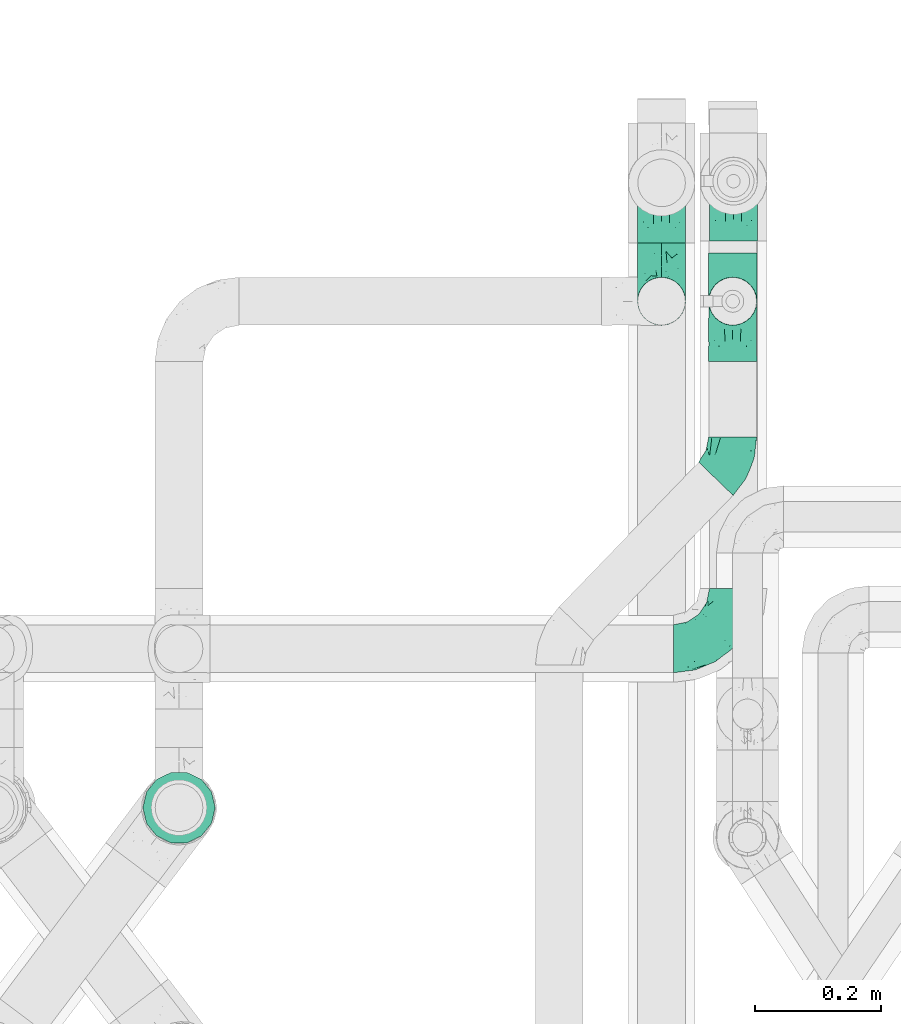
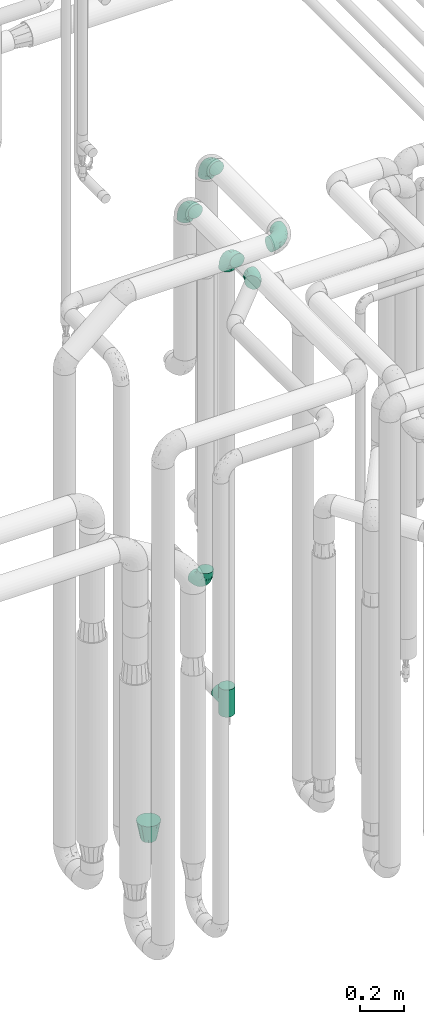
# One storey, part 672 of 827: 8 flow fittings.
"""IFC2X3 building model written with IfcOpenShell, lengths in millimetres."""

from ifc_helpers import new_model, entity, si_unit, converted_unit, derived_unit, direction, frame, origin, place, context, subcontext, project, spatial, faceted_brep, source, transform, mapped, material, type_object, type_shapes, element, save


model = new_model("IFC2X3")

# Units and contexts
model_context = context("Model", 3, precision=0.01, world=origin(), true_north=direction((6.12303176911189e-17, 1.0)))
body_context = subcontext(model_context, "Body", "Model", "MODEL_VIEW")
ifc_project = project(units=[si_unit("LENGTHUNIT", "METRE", prefix="MILLI"), si_unit("AREAUNIT", "SQUARE_METRE"), si_unit("VOLUMEUNIT", "CUBIC_METRE"), converted_unit("PLANEANGLEUNIT", "DEGREE", entity("IfcRatioMeasure", 0.0174532925199433), si_unit("PLANEANGLEUNIT", "RADIAN"), dimensions=[0, 0, 0, 0, 0, 0, 0]), si_unit("MASSUNIT", "GRAM", prefix="KILO"), derived_unit("MASSDENSITYUNIT", [(si_unit("MASSUNIT", "GRAM", prefix="KILO"), 1), (si_unit("LENGTHUNIT", "METRE"), -3)]), derived_unit("MOMENTOFINERTIAUNIT", [(si_unit("LENGTHUNIT", "METRE"), 4)]), si_unit("TIMEUNIT", "SECOND"), si_unit("FREQUENCYUNIT", "HERTZ"), si_unit("THERMODYNAMICTEMPERATUREUNIT", "DEGREE_CELSIUS"), derived_unit("THERMALTRANSMITTANCEUNIT", [(si_unit("MASSUNIT", "GRAM", prefix="KILO"), 1), (si_unit("THERMODYNAMICTEMPERATUREUNIT", "KELVIN"), -1), (si_unit("TIMEUNIT", "SECOND"), -3)]), derived_unit("VOLUMETRICFLOWRATEUNIT", [(si_unit("LENGTHUNIT", "METRE"), 3), (si_unit("TIMEUNIT", "SECOND"), -1)]), derived_unit("MASSFLOWRATEUNIT", [(si_unit("MASSUNIT", "GRAM", prefix="KILO"), 1), (si_unit("TIMEUNIT", "SECOND"), -1)]), derived_unit("ROTATIONALFREQUENCYUNIT", [(si_unit("TIMEUNIT", "SECOND"), -1)]), si_unit("ELECTRICCURRENTUNIT", "AMPERE"), si_unit("ELECTRICVOLTAGEUNIT", "VOLT"), si_unit("POWERUNIT", "WATT"), si_unit("FORCEUNIT", "NEWTON", prefix="KILO"), si_unit("ILLUMINANCEUNIT", "LUX"), si_unit("LUMINOUSFLUXUNIT", "LUMEN"), si_unit("LUMINOUSINTENSITYUNIT", "CANDELA"), derived_unit("USERDEFINED", [(si_unit("MASSUNIT", "GRAM", prefix="KILO"), -1), (si_unit("LENGTHUNIT", "METRE"), -2), (si_unit("TIMEUNIT", "SECOND"), 3), (si_unit("LUMINOUSFLUXUNIT", "LUMEN"), 1)]), derived_unit("LINEARVELOCITYUNIT", [(si_unit("LENGTHUNIT", "METRE"), 1), (si_unit("TIMEUNIT", "SECOND"), -1)]), si_unit("PRESSUREUNIT", "PASCAL"), derived_unit("USERDEFINED", [(si_unit("LENGTHUNIT", "METRE"), -2), (si_unit("MASSUNIT", "GRAM", prefix="KILO"), 1), (si_unit("TIMEUNIT", "SECOND"), -2)]), derived_unit("LINEARFORCEUNIT", [(si_unit("MASSUNIT", "GRAM", prefix="KILO"), 1), (si_unit("LENGTHUNIT", "METRE"), 1), (si_unit("TIMEUNIT", "SECOND"), -2), (si_unit("LENGTHUNIT", "METRE"), -1)]), derived_unit("PLANARFORCEUNIT", [(si_unit("MASSUNIT", "GRAM", prefix="KILO"), 1), (si_unit("LENGTHUNIT", "METRE"), 1), (si_unit("TIMEUNIT", "SECOND"), -2), (si_unit("LENGTHUNIT", "METRE"), -2)])], contexts=[model_context])

# Site, building, storey
site_placement = place(None, origin())
site = spatial("IfcSite", under=ifc_project, at=site_placement, CompositionType="ELEMENT")
building_placement = place(site_placement, origin())
building = spatial("IfcBuilding", under=site, at=building_placement, CompositionType="ELEMENT")
storey_placement = place(building_placement, frame((0.0, 0.0, 28200.0)))
storey = spatial("IfcBuildingStorey", under=building, at=storey_placement, Name="08", CompositionType="ELEMENT", Elevation=28200.0)

# Flow fittings
ifc_material = material()
pipe_fitting_type_1 = type_object("IfcPipeFittingType", Name="ADSK_1", PredefinedType="NOTDEFINED", material=ifc_material)
shared_shape_1 = source(origin(), body_context, "Body", "Brep", [
    faceted_brep([(-95.0, 19.02, -32.95), (-95.0, 9.85, -36.75), (-95.0, 0.0, -38.05), (-95.0, -9.85, -36.75), (-95.0, -19.03, -32.95), (-95.0, -26.91, -26.91), (-95.0, -32.95, -19.03), (-95.0, -36.75, -9.85), (-95.0, -38.05, 0.0), (-95.0, -36.75, 9.85), (-95.0, -32.95, 19.02), (-95.0, -26.91, 26.91), (-95.0, -19.03, 32.95), (-95.0, -9.85, 36.75), (-95.0, 0.0, 38.05), (-95.0, 9.85, 36.75), (-95.0, 19.02, 32.95), (-95.0, 26.91, 26.91), (-95.0, 32.95, 19.02), (-95.0, 36.75, 9.85), (-95.0, 38.05, 0.0), (-95.0, 36.75, -9.85), (-95.0, 32.95, -19.03), (-95.0, 26.91, -26.91), (0.0, 95.0, -38.05), (-9.85, 95.0, -36.75), (-19.02, 95.0, -32.95), (-26.91, 95.0, -26.91), (-32.95, 95.0, -19.03), (-36.75, 95.0, -9.85), (-38.05, 95.0, 0.0), (-36.75, 95.0, 9.85), (-32.95, 95.0, 19.02), (-26.91, 95.0, 26.91), (-19.02, 95.0, 32.95), (-9.85, 95.0, 36.75), (0.0, 95.0, 38.05), (9.85, 95.0, 36.75), (19.03, 95.0, 32.95), (26.91, 95.0, 26.91), (32.95, 95.0, 19.02), (36.75, 95.0, 9.85), (38.05, 95.0, 0.0), (36.75, 95.0, -9.85), (32.95, 95.0, -19.03), (26.91, 95.0, -26.91), (19.03, 95.0, -32.95), (9.85, 95.0, -36.75), (-7.99, -4.96, 6.3), (-0.92, 0.92, 0.0), (4.62, 8.1, 8.01), (-76.19, -35.57, 0.0), (-64.32, -32.32, 12.43), (20.51, 62.45, 28.68), (-60.56, -33.52, 0.0), (-70.4, -13.47, 34.42), (-39.61, -5.88, 32.32), (-49.6, 2.07, 37.1), (-70.34, -28.81, 21.71), (14.64, 40.81, 26.5), (5.88, 39.61, 32.32), (3.59, 20.77, 25.31), (-40.45, 68.06, 16.75), (-62.45, -20.51, 28.68), (-44.52, -26.87, 0.0), (-28.47, -20.22, 0.0), (-26.43, -17.83, 8.75), (-76.1, 39.63, 10.76), (-72.74, 37.58, 18.19), (-60.35, 46.18, 14.61), (-13.4, 13.4, 32.12), (-20.77, -3.59, 25.31), (-14.66, 81.47, 35.56), (-6.22, 71.26, 37.92), (-57.5, 42.48, 22.79), (-15.0, 34.74, 37.7), (-27.1, 12.08, 36.05), (-9.2, 28.81, 35.63), (-79.98, 23.7, 30.95), (-73.68, -4.3, 37.48), (-30.74, 21.67, 37.97), (-62.36, 47.59, 6.79), (-72.71, 32.83, 24.69), (-67.42, 7.02, 37.95), (-32.13, 75.27, 24.51), (-43.46, 51.47, 26.26), (-24.98, 73.15, 31.29), (20.59, 41.28, 19.85), (7.79, 16.09, 15.86), (-73.21, 42.39, 0.0), (-54.73, 54.73, 0.0), (-73.44, 15.79, 35.79), (-5.94, 4.32, 20.43), (28.81, 70.34, 21.71), (32.32, 64.32, 12.43), (-53.59, 26.2, 35.09), (-52.02, 19.31, 37.21), (21.38, 33.53, 10.34), (26.87, 44.52, 0.0), (-48.28, 12.14, 38.05), (4.3, 73.68, 37.48), (-44.08, -25.52, 12.79), (-41.28, -20.59, 19.85), (35.57, 76.19, 0.0), (-47.26, 54.3, 20.18), (-47.4, 61.99, 8.58), (-42.39, 73.21, 0.0), (-39.67, 78.86, 7.21), (-45.69, 36.84, 33.11), (-32.83, 50.13, 33.35), (13.47, 70.4, 34.42), (-18.25, 63.73, 36.07), (-40.63, -13.75, 27.22), (-16.63, 46.37, 37.95), (-53.47, 38.79, 28.59), (-26.07, 48.54, 36.15), (-34.51, 34.51, 36.86), (-2.07, 49.6, 37.1), (-22.79, -10.49, 19.23), (-61.73, 28.67, 31.87), (9.65, 14.7, 0.0), (20.22, 28.47, 0.0), (33.52, 60.56, 0.0), (-11.42, -5.44, 13.25), (-14.7, -9.65, 0.0), (-81.47, 14.66, -35.56), (-62.45, -20.51, -28.68), (-71.26, 6.22, -37.92), (-75.27, 32.13, -24.51), (-73.15, 24.98, -31.29), (13.47, 70.4, -34.42), (5.88, 39.61, -32.32), (-2.07, 49.6, -37.1), (-78.86, 39.67, -7.21), (-70.4, -13.47, -34.42), (-39.61, -5.88, -32.32), (-61.99, 47.4, -8.58), (32.32, 64.32, -12.43), (28.81, 70.34, -21.71), (-63.73, 18.25, -36.07), (-50.13, 32.83, -33.35), (4.3, 73.68, -37.48), (-7.02, 67.42, -37.95), (-39.63, 76.1, -10.76), (-46.18, 60.35, -14.61), (-47.59, 62.36, -6.79), (-64.32, -32.32, -12.43), (-26.2, 53.59, -35.09), (-15.79, 73.44, -35.79), (-19.31, 52.02, -37.21), (-37.58, 72.74, -18.19), (-70.34, -28.81, -21.71), (-42.48, 57.5, -22.79), (-38.79, 53.47, -28.59), (-51.47, 43.46, -26.26), (-32.83, 72.71, -24.69), (-46.37, 16.63, -37.95), (-73.68, -4.3, -37.48), (-41.28, -20.59, -19.85), (-44.08, -25.52, -12.79), (13.75, 40.63, -27.22), (20.51, 62.45, -28.68), (-68.06, 40.45, -16.75), (-54.3, 47.26, -20.18), (-12.14, 48.28, -38.05), (-21.67, 30.74, -37.97), (-36.84, 45.69, -33.11), (-11.42, -5.44, -13.25), (7.79, 16.09, -15.86), (4.62, 8.1, -8.01), (-23.7, 79.98, -30.95), (-26.43, -17.83, -8.75), (-7.99, -4.96, -6.3), (-40.81, -14.64, -26.5), (-20.77, -3.59, -25.31), (-34.74, 15.0, -37.7), (-12.08, 27.1, -36.05), (-28.81, 9.2, -35.63), (-22.79, -10.49, -19.23), (21.38, 33.53, -10.34), (20.59, 41.28, -19.85), (-48.54, 26.07, -36.15), (-49.6, 2.07, -37.1), (-13.4, 13.4, -32.12), (3.59, 20.77, -25.31), (-28.67, 61.73, -31.87), (-34.51, 34.51, -36.86), (-5.94, 4.32, -20.43)], [[[0, 1, 2, 3, 4, 5, 6, 7, 8, 9, 10, 11, 12, 13, 14, 15, 16, 17, 18, 19, 20, 21, 22, 23]], [[24, 25, 26, 27, 28, 29, 30, 31, 32, 33, 34, 35, 36, 37, 38, 39, 40, 41, 42, 43, 44, 45, 46, 47]], [[48, 49, 50]], [[51, 52, 9]], [[53, 39, 38]], [[9, 52, 10]], [[54, 52, 51]], [[55, 56, 57]], [[11, 10, 58]], [[59, 60, 61]], [[32, 31, 62]], [[63, 12, 11]], [[63, 55, 12]], [[64, 65, 66]], [[67, 68, 69]], [[70, 56, 71]], [[35, 72, 73]], [[69, 68, 74]], [[75, 76, 77]], [[16, 78, 17]], [[13, 79, 14]], [[76, 75, 80]], [[67, 69, 81]], [[18, 17, 82]], [[14, 79, 83]], [[20, 19, 67]], [[84, 85, 86]], [[87, 61, 88]], [[89, 81, 90]], [[18, 82, 68]], [[15, 91, 16]], [[14, 83, 15]], [[71, 92, 61]], [[17, 78, 82]], [[93, 87, 94]], [[95, 91, 96]], [[97, 98, 94]], [[86, 72, 34]], [[96, 99, 80]], [[37, 36, 100]], [[40, 39, 93]], [[40, 94, 41]], [[64, 66, 101]], [[93, 94, 40]], [[58, 102, 63]], [[94, 103, 41]], [[94, 87, 97]], [[104, 69, 74]], [[34, 33, 86]], [[105, 69, 104]], [[52, 58, 10]], [[106, 107, 30]], [[108, 109, 85]], [[105, 106, 90]], [[53, 110, 60]], [[86, 111, 72]], [[86, 109, 111]], [[33, 84, 86]], [[12, 55, 13]], [[112, 56, 63]], [[110, 38, 37]], [[34, 72, 35]], [[36, 35, 73]], [[111, 113, 73]], [[105, 107, 106]], [[110, 53, 38]], [[74, 114, 85]], [[91, 15, 83]], [[105, 90, 81]], [[107, 62, 31]], [[33, 32, 84]], [[115, 109, 116]], [[111, 115, 113]], [[100, 73, 117]], [[56, 55, 63]], [[79, 55, 57]], [[102, 118, 112]], [[56, 70, 76]], [[100, 110, 37]], [[117, 77, 60]], [[117, 60, 110]], [[60, 70, 61]], [[58, 52, 101]], [[63, 11, 58]], [[39, 53, 93]], [[87, 93, 53]], [[96, 91, 83]], [[78, 91, 119]], [[32, 62, 84]], [[84, 62, 104]], [[86, 85, 109]], [[85, 114, 108]], [[80, 113, 116]], [[117, 73, 113]], [[80, 116, 96]], [[80, 57, 76]], [[71, 112, 118]], [[61, 87, 59]], [[62, 107, 105]], [[97, 120, 121]], [[70, 71, 61]], [[71, 118, 92]], [[73, 100, 36]], [[110, 100, 117]], [[55, 79, 13]], [[83, 79, 57]], [[96, 83, 99]], [[116, 108, 95]], [[50, 97, 88]], [[97, 87, 88]], [[50, 49, 120]], [[122, 94, 98]], [[89, 20, 67]], [[105, 81, 69]], [[89, 67, 81]], [[68, 19, 18]], [[68, 67, 19]], [[74, 68, 82]], [[114, 82, 119]], [[74, 85, 104]], [[82, 114, 74]], [[114, 119, 108]], [[95, 108, 119]], [[116, 109, 108]], [[123, 48, 50]], [[97, 50, 120]], [[123, 50, 88]], [[91, 95, 119]], [[116, 95, 96]], [[84, 104, 85]], [[104, 62, 105]], [[83, 57, 99]], [[57, 80, 99]], [[66, 48, 123]], [[66, 124, 48]], [[118, 66, 123]], [[124, 66, 65]], [[66, 118, 101]], [[54, 64, 52]], [[124, 49, 48]], [[30, 107, 31]], [[91, 78, 16]], [[82, 78, 119]], [[56, 76, 57]], [[77, 76, 70]], [[60, 77, 70]], [[77, 117, 75]], [[117, 113, 75]], [[113, 80, 75]], [[9, 8, 51]], [[103, 94, 122]], [[103, 42, 41]], [[73, 72, 111]], [[113, 115, 116]], [[111, 109, 115]], [[102, 112, 63]], [[71, 56, 112]], [[118, 102, 101]], [[92, 123, 88]], [[123, 92, 118]], [[61, 92, 88]], [[87, 53, 59]], [[60, 59, 53]], [[97, 121, 98]], [[58, 101, 102]], [[64, 101, 52]], [[125, 1, 0]], [[126, 5, 4]], [[2, 1, 127]], [[1, 125, 127]], [[128, 129, 23]], [[130, 131, 132]], [[89, 133, 20]], [[126, 134, 135]], [[136, 89, 90]], [[137, 138, 44]], [[139, 129, 140]], [[24, 141, 142]], [[143, 144, 145]], [[125, 129, 139]], [[6, 146, 7]], [[147, 148, 149]], [[146, 51, 7]], [[143, 150, 144]], [[146, 6, 151]], [[152, 153, 154]], [[126, 4, 134]], [[0, 23, 129]], [[28, 155, 150]], [[43, 42, 103]], [[54, 146, 64]], [[139, 156, 127]], [[157, 3, 2]], [[151, 158, 159]], [[160, 131, 161]], [[22, 21, 162]], [[136, 144, 163]], [[149, 164, 165]], [[24, 142, 25]], [[166, 140, 154]], [[154, 129, 128]], [[143, 30, 29]], [[167, 168, 169]], [[155, 28, 27]], [[26, 170, 27]], [[171, 167, 172]], [[26, 25, 148]], [[27, 170, 155]], [[173, 135, 174]], [[144, 150, 152]], [[175, 176, 177]], [[24, 47, 141]], [[45, 161, 46]], [[148, 25, 142]], [[176, 175, 165]], [[64, 159, 171]], [[138, 45, 44]], [[130, 46, 161]], [[137, 44, 43]], [[178, 159, 158]], [[137, 103, 122]], [[163, 144, 152]], [[136, 133, 89]], [[103, 137, 43]], [[6, 5, 151]], [[178, 158, 173]], [[134, 4, 3]], [[178, 173, 174]], [[137, 98, 179]], [[145, 90, 106]], [[138, 180, 161]], [[46, 130, 47]], [[136, 90, 145]], [[133, 162, 21]], [[23, 22, 128]], [[139, 140, 181]], [[139, 181, 156]], [[157, 127, 182]], [[157, 134, 3]], [[182, 177, 135]], [[182, 135, 134]], [[135, 183, 174]], [[131, 130, 161]], [[141, 130, 132]], [[160, 180, 184]], [[131, 183, 176]], [[5, 126, 151]], [[158, 151, 126]], [[180, 138, 137]], [[161, 45, 138]], [[149, 148, 142]], [[170, 148, 185]], [[22, 162, 128]], [[128, 162, 163]], [[129, 154, 140]], [[154, 153, 166]], [[165, 156, 186]], [[182, 127, 156]], [[165, 186, 149]], [[165, 132, 176]], [[131, 184, 183]], [[187, 167, 178]], [[184, 168, 187]], [[167, 169, 172]], [[184, 180, 168]], [[174, 183, 184]], [[127, 157, 2]], [[134, 157, 182]], [[130, 141, 47]], [[142, 141, 132]], [[149, 142, 164]], [[186, 166, 147]], [[180, 179, 168]], [[169, 179, 120]], [[137, 179, 180]], [[179, 121, 120]], [[106, 30, 143]], [[136, 145, 144]], [[106, 143, 145]], [[150, 29, 28]], [[150, 143, 29]], [[152, 150, 155]], [[153, 155, 185]], [[152, 154, 163]], [[155, 153, 152]], [[153, 185, 166]], [[147, 166, 185]], [[186, 140, 166]], [[169, 120, 49]], [[169, 49, 172]], [[179, 169, 168]], [[148, 147, 185]], [[186, 147, 149]], [[128, 163, 154]], [[163, 162, 136]], [[142, 132, 164]], [[132, 165, 164]], [[171, 124, 65]], [[124, 171, 172]], [[64, 146, 159]], [[171, 159, 178]], [[171, 65, 64]], [[172, 49, 124]], [[162, 133, 136]], [[20, 133, 21]], [[148, 170, 26]], [[155, 170, 185]], [[131, 176, 132]], [[177, 176, 183]], [[135, 177, 183]], [[177, 182, 175]], [[182, 156, 175]], [[156, 165, 175]], [[51, 146, 54]], [[51, 8, 7]], [[129, 125, 0]], [[127, 125, 139]], [[140, 186, 181]], [[156, 181, 186]], [[158, 126, 173]], [[135, 173, 126]], [[187, 178, 174]], [[171, 178, 167]], [[184, 187, 174]], [[167, 187, 168]], [[180, 160, 161]], [[184, 131, 160]], [[98, 137, 122]], [[98, 121, 179]], [[151, 159, 146]]]),
])
type_shapes(pipe_fitting_type_1, [shared_shape_1])
for number, where, z_axis, x_axis, name in (
    (1, (46669.38, 15088.04, 3000.0), (-1.0, 0.0, 0.0), (0.0, 1.0, 0.0), "ADSK_1"),
    (2, (46556.64, 15088.04, 1165.0), (1.0, 0.0, 0.0), (0.0, 0.0, -1.0), "ADSK_1"),
    (3, (46556.77, 15275.36, 3200.05), (-1.0, 0.0, 0.0), (0.0, 1.0, 0.0), "ADSK_1"),
):
    element("IfcFlowFitting", number, at=place(storey_placement, frame(where, z_axis=z_axis, x_axis=x_axis)), inside=storey, type_object=pipe_fitting_type_1, material=ifc_material, Name=name, ObjectType="ADSK_1", context=body_context, shape_type="MappedRepresentation", body=[
        mapped(shared_shape_1, transform((0.0, 0.0, 0.0), scale=1.0)),
    ])
flow_fitting_1_placement = place(storey_placement, frame((46670.56, 14538.08, 3400.0)))
element("IfcFlowFitting", 4, at=flow_fitting_1_placement, inside=storey, type_object=pipe_fitting_type_1, material=ifc_material, Name="ADSK_1", ObjectType="ADSK_1", context=body_context, shape_type="MappedRepresentation", body=[
    mapped(shared_shape_1, transform((0.0, 0.0, 0.0), scale=1.0)),
])
flow_fitting_2_placement = place(storey_placement, frame((46670.56, 15278.08, 3400.0), z_axis=(-1.0, 0.0, 0.0), x_axis=(0.0, 1.0, 0.0)))
element("IfcFlowFitting", 5, at=flow_fitting_2_placement, inside=storey, type_object=pipe_fitting_type_1, material=ifc_material, Name="ADSK_1", ObjectType="ADSK_1", context=body_context, shape_type="MappedRepresentation", body=[
    mapped(shared_shape_1, transform((0.0, 0.0, 0.0), scale=1.0)),
])
pipe_fitting_type_2 = type_object("IfcPipeFittingType", Name="ADSK_1", PredefinedType="NOTDEFINED", material=ifc_material)
shared_shape_2 = source(origin(), body_context, "Body", "Brep", [
    faceted_brep([(-76.0, 9.85, -36.75), (-76.0, 0.0, -38.05), (-76.0, -9.85, -36.75), (-76.0, -19.03, -32.95), (-76.0, -22.97, -29.93), (-76.0, -26.91, -26.91), (-76.0, -29.93, -22.97), (-76.0, -32.95, -19.03), (-76.0, -34.85, -14.44), (-76.0, -36.75, -9.85), (-76.0, -38.05, 0.0), (-76.0, -36.75, 9.85), (-76.0, -34.85, 14.44), (-76.0, -32.95, 19.02), (-76.0, -29.93, 22.97), (-76.0, -26.91, 26.91), (-76.0, -22.97, 29.93), (-76.0, -19.03, 32.95), (-76.0, -9.85, 36.75), (-76.0, 0.0, 38.05), (-76.0, 9.85, 36.75), (-76.0, 19.02, 32.95), (-76.0, 26.91, 26.91), (-76.0, 32.95, 19.02), (-76.0, 36.75, 9.85), (-76.0, 38.05, 0.0), (-76.0, 36.75, -9.85), (-76.0, 32.95, -19.03), (-76.0, 26.91, -26.91), (-76.0, 19.02, -32.95), (76.0, 26.91, -26.91), (76.0, 32.95, -19.03), (76.0, 36.75, -9.85), (76.0, 38.05, 0.0), (76.0, 36.75, 9.85), (76.0, 32.95, 19.02), (76.0, 26.91, 26.91), (76.0, 19.02, 32.95), (76.0, 9.85, 36.75), (76.0, 0.0, 38.05), (76.0, -9.85, 36.75), (76.0, -19.03, 32.95), (76.0, -22.97, 29.93), (76.0, -26.91, 26.91), (76.0, -29.93, 22.97), (76.0, -32.95, 19.02), (76.0, -34.85, 14.44), (76.0, -36.75, 9.85), (76.0, -38.05, 0.0), (76.0, -36.75, -9.85), (76.0, -34.85, -14.44), (76.0, -32.95, -19.03), (76.0, -29.93, -22.97), (76.0, -26.91, -26.91), (76.0, -22.97, -29.93), (76.0, -19.03, -32.95), (76.0, -9.85, -36.75), (76.0, 0.0, -38.05), (76.0, 9.85, -36.75), (76.0, 19.02, -32.95), (36.99, -36.99, 8.94), (38.05, -38.05, 0.0), (-36.99, -36.99, 8.94), (-38.05, -38.05, 0.0), (35.51, -35.51, 12.97), (34.04, -34.04, 17.0), (18.81, -18.81, 33.08), (29.74, -29.74, 23.73), (24.56, -24.56, 29.06), (-35.51, -35.51, 12.97), (-34.04, -34.04, 17.0), (-18.81, -18.81, 33.08), (-29.74, -29.74, 23.73), (-24.56, -24.56, 29.06), (-12.7, -12.7, 35.87), (6.4, -6.4, 37.51), (12.7, -12.7, 35.87), (0.0, 0.0, 38.05), (-6.4, -6.4, 37.51), (6.4, -6.4, -37.51), (0.0, 0.0, -38.05), (12.7, -12.7, -35.87), (-24.56, -24.56, -29.06), (-6.4, -6.4, -37.51), (-35.51, -35.51, -12.97), (-36.99, -36.99, -8.94), (-29.74, -29.74, -23.73), (-12.7, -12.7, -35.87), (18.81, -18.81, -33.08), (24.56, -24.56, -29.06), (-34.04, -34.04, -17.0), (29.74, -29.74, -23.73), (36.99, -36.99, -8.94), (35.51, -35.51, -12.97), (34.04, -34.04, -17.0), (-18.81, -18.81, -33.08), (9.85, -76.0, -36.75), (19.03, -76.0, -32.95), (26.91, -76.0, -26.91), (32.95, -76.0, -19.03), (36.75, -76.0, -9.85), (38.05, -76.0, 0.0), (36.75, -76.0, 9.85), (32.95, -76.0, 19.02), (26.91, -76.0, 26.91), (19.03, -76.0, 32.95), (9.85, -76.0, 36.75), (0.0, -76.0, 38.05), (-9.85, -76.0, 36.75), (-19.02, -76.0, 32.95), (-26.91, -76.0, 26.91), (-32.95, -76.0, 19.02), (-36.75, -76.0, 9.85), (-38.05, -76.0, 0.0), (-36.75, -76.0, -9.85), (-32.95, -76.0, -19.03), (-26.91, -76.0, -26.91), (-19.02, -76.0, -32.95), (-9.85, -76.0, -36.75), (0.0, -76.0, -38.05)], [[[0, 1, 2, 3, 4, 5, 6, 7, 8, 9, 10, 11, 12, 13, 14, 15, 16, 17, 18, 19, 20, 21, 22, 23, 24, 25, 26, 27, 28, 29]], [[30, 31, 32, 33, 34, 35, 36, 37, 38, 39, 40, 41, 42, 43, 44, 45, 46, 47, 48, 49, 50, 51, 52, 53, 54, 55, 56, 57, 58, 59]], [[48, 47, 60]], [[60, 61, 48]], [[62, 10, 63]], [[47, 46, 64]], [[46, 45, 65]], [[41, 66, 42]], [[43, 67, 45, 44]], [[67, 43, 68]], [[45, 67, 65]], [[68, 43, 42]], [[11, 69, 12]], [[70, 12, 69]], [[10, 62, 11]], [[11, 62, 69]], [[71, 17, 16]], [[72, 73, 15]], [[72, 15, 14, 13]], [[15, 73, 16]], [[71, 74, 17]], [[72, 13, 70]], [[46, 65, 64]], [[42, 66, 68]], [[40, 39, 75]], [[47, 64, 60]], [[66, 41, 76]], [[75, 76, 40]], [[75, 39, 77]], [[78, 77, 19]], [[76, 41, 40]], [[23, 22, 36, 35]], [[24, 23, 35, 34]], [[21, 20, 38, 37]], [[22, 21, 37, 36]], [[38, 20, 19, 77, 39]], [[25, 24, 34, 33]], [[70, 13, 12]], [[78, 18, 74]], [[18, 78, 19]], [[18, 17, 74]], [[71, 16, 73]], [[28, 27, 31, 30]], [[26, 32, 31, 27]], [[25, 33, 32, 26]], [[29, 28, 30, 59]], [[57, 56, 79]], [[58, 57, 80, 1, 0]], [[79, 56, 81]], [[82, 5, 4]], [[59, 58, 0, 29]], [[56, 55, 81]], [[57, 79, 80]], [[80, 83, 1]], [[9, 84, 85]], [[86, 7, 6, 5]], [[83, 87, 2]], [[1, 83, 2]], [[87, 3, 2]], [[88, 54, 89]], [[54, 53, 89]], [[8, 90, 84]], [[88, 55, 54]], [[91, 89, 53]], [[52, 51, 91, 53]], [[55, 88, 81]], [[49, 92, 93]], [[92, 49, 48]], [[94, 50, 93]], [[61, 92, 48]], [[85, 63, 10]], [[51, 94, 91]], [[82, 4, 95]], [[49, 93, 50]], [[4, 3, 95]], [[5, 82, 86]], [[94, 51, 50]], [[95, 3, 87]], [[9, 8, 84]], [[90, 8, 7]], [[9, 85, 10]], [[90, 7, 86]], [[96, 97, 98, 99, 100, 101, 102, 103, 104, 105, 106, 107, 108, 109, 110, 111, 112, 113, 114, 115, 116, 117, 118, 119]], [[62, 63, 113]], [[112, 62, 113]], [[110, 109, 73]], [[72, 111, 110]], [[70, 112, 111]], [[74, 109, 108]], [[112, 70, 69, 62]], [[73, 72, 110]], [[70, 111, 72]], [[74, 71, 109]], [[107, 77, 78]], [[74, 108, 78]], [[73, 109, 71]], [[78, 108, 107]], [[75, 107, 106]], [[105, 76, 106]], [[103, 102, 65]], [[67, 104, 103]], [[68, 105, 104]], [[60, 102, 101]], [[68, 66, 105]], [[76, 75, 106]], [[66, 76, 105]], [[61, 60, 101]], [[65, 67, 103]], [[102, 60, 64, 65]], [[68, 104, 67]], [[107, 75, 77]], [[61, 101, 92]], [[100, 92, 101]], [[98, 97, 89]], [[94, 100, 99]], [[98, 91, 99]], [[81, 97, 96]], [[100, 94, 93, 92]], [[89, 91, 98]], [[94, 99, 91]], [[81, 88, 97]], [[119, 80, 79]], [[81, 96, 79]], [[89, 97, 88]], [[79, 96, 119]], [[83, 119, 118]], [[117, 87, 118]], [[115, 114, 90]], [[86, 116, 115]], [[82, 117, 116]], [[85, 114, 113]], [[82, 95, 117]], [[87, 83, 118]], [[95, 87, 117]], [[63, 85, 113]], [[90, 86, 115]], [[114, 85, 84, 90]], [[82, 116, 86]], [[119, 83, 80]]]),
])
type_shapes(pipe_fitting_type_2, [shared_shape_2])
flow_fitting_3_placement = place(storey_placement, frame((46669.38, 15088.04, 494.0), z_axis=(-1.0, 0.0, 0.0), x_axis=(0.0, 0.0, -1.0)))
element("IfcFlowFitting", 6, at=flow_fitting_3_placement, inside=storey, type_object=pipe_fitting_type_2, material=ifc_material, Name="ADSK_1", ObjectType="ADSK_1", context=body_context, shape_type="MappedRepresentation", body=[
    mapped(shared_shape_2, transform((0.0, 0.0, 0.0), scale=1.0)),
])
pipe_fitting_type_3 = type_object("IfcPipeFittingType", Name="ADSK_1", PredefinedType="NOTDEFINED", material=ifc_material)
shared_shape_3 = source(origin(), body_context, "Body", "Brep", [
    faceted_brep([(-38.38, 19.02, -32.95), (-38.38, 9.85, -36.75), (-38.38, 0.0, -38.05), (-38.38, -9.85, -36.75), (-38.38, -19.03, -32.95), (-38.38, -26.91, -26.91), (-38.38, -32.95, -19.03), (-38.38, -36.75, -9.85), (-38.38, -38.05, 0.0), (-38.38, -36.75, 9.85), (-38.38, -32.95, 19.02), (-38.38, -26.91, 26.91), (-38.38, -19.03, 32.95), (-38.38, -9.85, 36.75), (-38.38, 0.0, 38.05), (-38.38, 9.85, 36.75), (-38.38, 19.02, 32.95), (-38.38, 26.91, 26.91), (-38.38, 32.95, 19.02), (-38.38, 36.75, 9.85), (-38.38, 38.05, 0.0), (-38.38, 36.75, -9.85), (-38.38, 32.95, -19.03), (-38.38, 26.91, -26.91), (20.77, 33.75, -36.75), (14.39, 40.35, -32.95), (8.92, 46.02, -26.91), (4.72, 50.37, -19.03), (2.08, 53.1, -9.85), (1.18, 54.03, 0.0), (2.08, 53.1, 9.85), (4.72, 50.37, 19.02), (8.92, 46.02, 26.91), (14.39, 40.35, 32.95), (20.77, 33.75, 36.75), (27.61, 26.66, 38.05), (34.45, 19.58, 36.75), (40.83, 12.98, 32.95), (46.3, 7.31, 26.91), (50.5, 2.96, 19.02), (53.14, 0.22, 9.85), (54.04, -0.71, 0.0), (53.14, 0.22, -9.85), (50.5, 2.96, -19.03), (46.3, 7.31, -26.91), (40.83, 12.98, -32.95), (34.45, 19.58, -36.75), (27.61, 26.66, -38.05), (-16.1, -28.69, 22.51), (-9.29, -32.27, 13.55), (8.9, -22.04, 21.74), (-19.56, -35.63, 0.0), (-4.69, -33.71, 0.0), (-12.93, -34.99, 6.7), (-10.8, -20.72, 29.56), (31.51, -9.45, 22.51), (5.49, -13.59, 30.96), (-19.25, -13.54, 34.88), (9.34, 20.78, 37.44), (-13.67, -2.83, 37.59), (-4.14, 10.25, 37.88), (-23.14, 5.66, 37.8), (22.16, -7.4, 29.56), (23.26, 3.63, 34.88), (-16.88, 16.63, 35.49), (-11.11, 27.51, 30.9), (-4.72, 36.0, 26.74), (10.35, -25.61, 14.72), (-19.03, 32.59, 23.84), (-15.82, 39.15, 15.48), (33.61, -16.18, 6.7), (38.82, -12.04, 0.0), (-12.9, 43.14, 7.91), (11.21, -27.75, 7.05), (11.97, 7.56, 37.59), (3.2, -7.92, 34.52), (29.1, -16.76, 13.55), (3.23, 25.33, 35.44), (-17.05, 42.2, 0.0), (11.05, -27.35, 0.0), (26.8, -20.99, 0.0), (-13.87, -2.87, -37.59), (-12.93, -34.99, -6.7), (11.15, -27.6, -7.86), (0.59, 23.68, -35.49), (-21.15, 8.46, -37.44), (-20.69, 39.99, -7.91), (-15.82, 39.15, -15.48), (22.16, -7.4, -29.56), (-21.62, 29.17, -26.74), (29.1, -16.76, -13.55), (-8.95, 36.66, -23.84), (11.8, 7.46, -37.59), (-19.92, 15.98, -35.44), (-9.29, -32.27, -13.55), (31.51, -9.45, -22.51), (-16.1, -28.69, -22.51), (8.9, -22.04, -21.74), (9.11, -25.93, -15.1), (-10.8, -20.72, -29.56), (5.49, -13.59, -30.96), (3.2, -7.92, -34.52), (23.26, 3.63, -34.88), (-19.25, -13.54, -34.88), (-11.11, 27.51, -30.9), (-4.14, 10.25, -37.88), (33.61, -16.18, -6.7), (12.71, 20.14, -37.8)], [[[0, 1, 2, 3, 4, 5, 6, 7, 8, 9, 10, 11, 12, 13, 14, 15, 16, 17, 18, 19, 20, 21, 22, 23]], [[24, 25, 26, 27, 28, 29, 30, 31, 32, 33, 34, 35, 36, 37, 38, 39, 40, 41, 42, 43, 44, 45, 46, 47]], [[48, 49, 50]], [[51, 52, 53]], [[12, 11, 54]], [[39, 38, 55]], [[54, 56, 57]], [[48, 11, 10]], [[34, 58, 35]], [[13, 12, 57]], [[59, 60, 61]], [[14, 13, 59]], [[62, 55, 38]], [[37, 36, 63]], [[61, 15, 14]], [[16, 64, 65]], [[9, 51, 53]], [[32, 66, 33]], [[49, 67, 50]], [[65, 17, 16]], [[18, 17, 68]], [[18, 68, 69]], [[19, 18, 69]], [[40, 70, 71]], [[72, 20, 19]], [[52, 73, 53]], [[49, 53, 73]], [[16, 15, 64]], [[74, 60, 59]], [[38, 37, 62]], [[75, 74, 59]], [[74, 36, 35]], [[66, 68, 65]], [[76, 39, 55]], [[77, 58, 34]], [[62, 37, 63]], [[17, 65, 68]], [[70, 40, 76]], [[49, 48, 10]], [[61, 64, 15]], [[56, 50, 62]], [[19, 69, 72]], [[10, 9, 49]], [[78, 72, 29]], [[48, 54, 11]], [[30, 72, 69]], [[75, 63, 74]], [[31, 69, 68]], [[55, 62, 50]], [[68, 66, 31]], [[57, 59, 13]], [[34, 33, 77]], [[77, 65, 64]], [[56, 75, 57]], [[74, 35, 58]], [[76, 40, 39]], [[54, 48, 50]], [[31, 30, 69]], [[76, 55, 50]], [[65, 77, 33]], [[60, 77, 64]], [[54, 57, 12]], [[59, 57, 75]], [[74, 63, 36]], [[63, 75, 56]], [[9, 8, 51]], [[73, 52, 79, 80]], [[9, 53, 49]], [[70, 73, 80]], [[73, 76, 67]], [[71, 70, 80]], [[71, 41, 40]], [[73, 70, 76]], [[77, 60, 58]], [[58, 60, 74]], [[59, 61, 14]], [[64, 61, 60]], [[73, 67, 49]], [[76, 50, 67]], [[29, 72, 30]], [[72, 78, 20]], [[50, 56, 54]], [[63, 56, 62]], [[33, 66, 65]], [[31, 66, 32]], [[3, 2, 81]], [[52, 82, 83]], [[25, 24, 84]], [[1, 85, 2]], [[21, 86, 87]], [[45, 44, 88]], [[0, 23, 89]], [[43, 42, 90]], [[91, 89, 22]], [[47, 46, 92]], [[28, 27, 87]], [[1, 0, 93]], [[82, 7, 94]], [[90, 95, 43]], [[96, 97, 98]], [[96, 94, 6]], [[5, 4, 99]], [[100, 101, 102]], [[7, 6, 94]], [[5, 96, 6]], [[103, 4, 3]], [[89, 91, 104]], [[99, 96, 5]], [[27, 26, 91]], [[20, 78, 86]], [[26, 104, 91]], [[29, 28, 86]], [[100, 97, 99]], [[104, 84, 93]], [[87, 22, 21]], [[27, 91, 87]], [[103, 99, 4]], [[84, 104, 25]], [[87, 91, 22]], [[105, 92, 81]], [[26, 25, 104]], [[42, 71, 106]], [[107, 24, 47]], [[102, 46, 45]], [[7, 82, 51]], [[43, 95, 44]], [[102, 88, 100]], [[95, 88, 44]], [[105, 107, 92]], [[97, 95, 90]], [[81, 2, 85]], [[106, 71, 80]], [[102, 92, 46]], [[101, 103, 81]], [[82, 94, 83]], [[101, 81, 92]], [[98, 90, 83]], [[107, 84, 24]], [[28, 87, 86]], [[93, 85, 1]], [[96, 99, 97]], [[88, 95, 97]], [[104, 93, 0]], [[105, 93, 84]], [[81, 103, 3]], [[103, 101, 100]], [[88, 102, 45]], [[92, 102, 101]], [[51, 82, 52]], [[51, 8, 7]], [[98, 83, 94]], [[106, 83, 90]], [[83, 80, 79, 52]], [[42, 41, 71]], [[83, 106, 80]], [[42, 106, 90]], [[93, 105, 85]], [[85, 105, 81]], [[92, 107, 47]], [[84, 107, 105]], [[20, 86, 21]], [[86, 78, 29]], [[97, 100, 88]], [[103, 100, 99]], [[0, 89, 104]], [[22, 89, 23]], [[96, 98, 94]], [[90, 98, 97]]]),
])
type_shapes(pipe_fitting_type_3, [shared_shape_3])
flow_fitting_4_placement = place(storey_placement, frame((46669.38, 14834.67, 3000.0), z_axis=(0.0, 0.0, 1.0), x_axis=(0.694658370459026, 0.719339800338624, 0.0)))
element("IfcFlowFitting", 7, at=flow_fitting_4_placement, inside=storey, type_object=pipe_fitting_type_3, material=ifc_material, Name="ADSK_1", ObjectType="ADSK_1", context=body_context, shape_type="MappedRepresentation", body=[
    mapped(shared_shape_3, transform((0.0, 0.0, 0.0), scale=1.0)),
])
pipe_fitting_type_4 = type_object("IfcPipeFittingType", Name="ADSK_1", PredefinedType="NOTDEFINED", material=ifc_material)
shared_shape_4 = source(origin(), body_context, "Body", "Brep", [
    faceted_brep([(102.0, -57.15, 0.0), (102.0, -54.32, -12.4), (102.0, -51.49, -24.8), (102.0, -43.56, -34.74), (102.0, -35.63, -44.68), (102.0, -24.17, -50.2), (102.0, -12.72, -55.72), (102.0, 0.0, -55.72), (102.0, 12.72, -55.72), (102.0, 24.17, -50.2), (102.0, 35.63, -44.68), (102.0, 43.56, -34.74), (102.0, 51.49, -24.8), (102.0, 54.32, -12.4), (102.0, 57.15, 0.0), (102.0, 54.32, 12.4), (102.0, 51.49, 24.8), (102.0, 43.56, 34.74), (102.0, 35.63, 44.68), (102.0, 24.17, 50.2), (102.0, 12.72, 55.72), (102.0, 0.0, 55.72), (102.0, -12.72, 55.72), (102.0, -24.17, 50.2), (102.0, -35.63, 44.68), (102.0, -43.56, 34.74), (102.0, -51.49, 24.8), (102.0, -54.32, 12.4), (0.0, 38.05, 0.0), (0.0, 35.5, -9.51), (0.0, 32.95, -19.02), (0.0, 25.99, -25.99), (0.0, 19.02, -32.95), (0.0, 9.51, -35.5), (0.0, 0.0, -38.05), (0.0, -9.51, -35.5), (0.0, -19.02, -32.95), (0.0, -25.99, -25.99), (0.0, -32.95, -19.02), (0.0, -35.5, -9.51), (0.0, -38.05, 0.0), (0.0, -35.5, 9.51), (0.0, -32.95, 19.03), (0.0, -25.99, 25.99), (0.0, -19.03, 32.95), (0.0, -9.51, 35.5), (0.0, 0.0, 38.05), (0.0, 9.51, 35.5), (0.0, 19.03, 32.95), (0.0, 25.99, 25.99), (0.0, 32.95, 19.03), (0.0, 35.5, 9.51)], [[[0, 1, 2, 3, 4, 5, 6, 7, 8, 9, 10, 11, 12, 13, 14, 15, 16, 17, 18, 19, 20, 21, 22, 23, 24, 25, 26, 27]], [[28, 29, 30, 31, 32, 33, 34, 35, 36, 37, 38, 39, 40, 41, 42, 43, 44, 45, 46, 47, 48, 49, 50, 51]], [[38, 2, 39]], [[11, 10, 31]], [[8, 34, 33]], [[3, 2, 38]], [[40, 39, 1]], [[28, 13, 29]], [[40, 1, 0]], [[32, 10, 9]], [[34, 8, 7, 6]], [[37, 36, 4]], [[39, 2, 1]], [[33, 32, 9]], [[38, 37, 3]], [[37, 4, 3]], [[5, 4, 36]], [[13, 28, 14]], [[10, 32, 31]], [[8, 33, 9]], [[35, 5, 36]], [[30, 11, 31]], [[29, 12, 30]], [[5, 35, 6]], [[35, 34, 6]], [[11, 30, 12]], [[13, 12, 29]], [[50, 16, 51]], [[25, 24, 43]], [[22, 46, 45]], [[17, 16, 50]], [[28, 51, 15]], [[40, 27, 41]], [[28, 15, 14]], [[44, 24, 23]], [[46, 22, 21, 20]], [[49, 48, 18]], [[51, 16, 15]], [[45, 44, 23]], [[50, 49, 17]], [[49, 18, 17]], [[19, 18, 48]], [[27, 40, 0]], [[24, 44, 43]], [[22, 45, 23]], [[47, 19, 48]], [[42, 25, 43]], [[41, 26, 42]], [[19, 47, 20]], [[47, 46, 20]], [[25, 42, 26]], [[27, 26, 41]]]),
])
type_shapes(pipe_fitting_type_4, [shared_shape_4])
flow_fitting_5_placement = place(storey_placement, frame((45793.07, 14286.62, 510.0), z_axis=(0.0, 1.0, 0.0), x_axis=(0.0, 0.0, 1.0)))
element("IfcFlowFitting", 8, at=flow_fitting_5_placement, inside=storey, type_object=pipe_fitting_type_4, material=ifc_material, Name="ADSK_1", ObjectType="ADSK_1", context=body_context, shape_type="MappedRepresentation", body=[
    mapped(shared_shape_4, transform((0.0, 0.0, 0.0), scale=1.0)),
])

save(model, "model.ifc")
